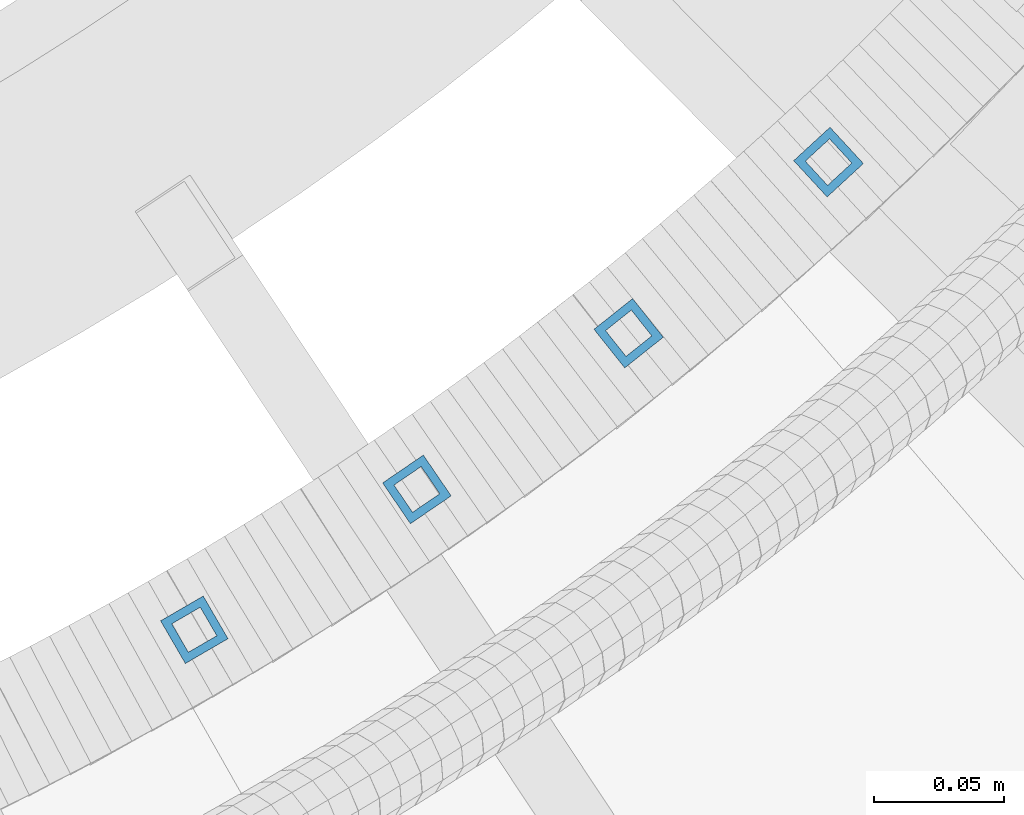
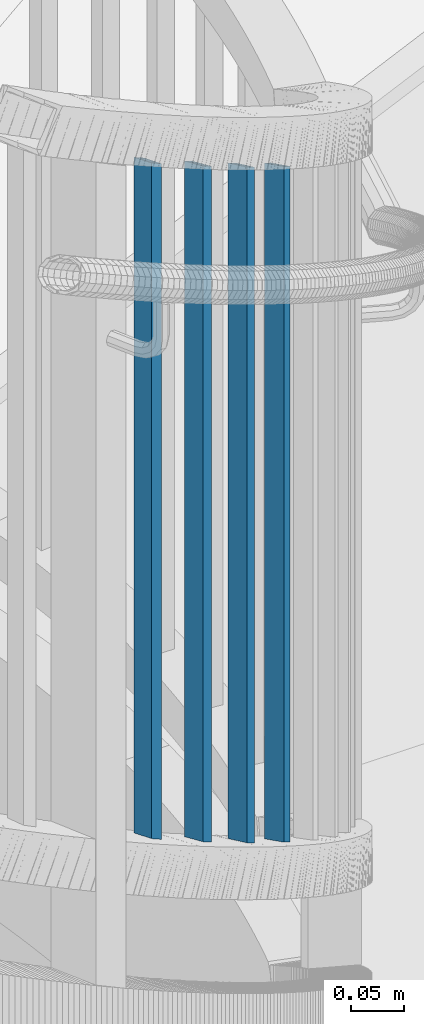
# One storey, part 259 of 975: 4 columns.
"""IFC2X3 building model written with IfcOpenShell, lengths in millimetres."""

from ifc_helpers import new_model, si_unit, frame, origin_with_axes, place, context, subcontext, project, spatial, faceted_brep, material, type_object, element, save


model = new_model("IFC2X3")

# Units and contexts
model_context = context("Model", 3, precision=1e-05, world=origin_with_axes())
body_context = subcontext(model_context, "Body", "Model", "MODEL_VIEW")
ifc_project = project(units=[si_unit("LENGTHUNIT", "METRE", prefix="MILLI"), si_unit("AREAUNIT", "SQUARE_METRE"), si_unit("VOLUMEUNIT", "CUBIC_METRE"), si_unit("MASSUNIT", "GRAM", prefix="KILO"), si_unit("TIMEUNIT", "SECOND"), si_unit("PLANEANGLEUNIT", "RADIAN"), si_unit("SOLIDANGLEUNIT", "STERADIAN"), si_unit("THERMODYNAMICTEMPERATUREUNIT", "DEGREE_CELSIUS"), si_unit("LUMINOUSINTENSITYUNIT", "LUMEN")], contexts=[model_context])

# Site, building, storey
site_placement = place(None, origin_with_axes())
site = spatial("IfcSite", under=ifc_project, at=site_placement, CompositionType="ELEMENT")
building_placement = place(site_placement, origin_with_axes())
building = spatial("IfcBuilding", under=site, at=building_placement, Name="Undefined", CompositionType="ELEMENT")
storey_placement = place(building_placement, origin_with_axes())
storey = spatial("IfcBuildingStorey", under=building, at=storey_placement, Name="Undefined", CompositionType="ELEMENT", Elevation=0.0)

# Columns
ifc_material = material()
column_type = type_object("IfcColumnType", Name="HSS3/4X3/4X.120_TUBES", PredefinedType="NOTDEFINED")
for number, where, z_axis, x_axis, name in (
    (1, (35436.091114407, 2195.81949765584, 2987.40328621885), (0.502295716094457, -0.864695908162607, 0.0), (0.0, 0.0, 1.0), "PICKET"),
    (2, (35521.9983422448, 2249.99253060321, 2920.72828621885), (0.563799962053774, -0.825911377078778, 0.0), (0.0, 0.0, 1.0), "PICKET"),
    (3, (35603.7420568337, 2310.26470012371, 2854.05328621885), (0.622323390073894, -0.782760243092951, 0.0), (0.0, 0.0, 1.0), "PICKET"),
    (4, (35680.8900781698, 2376.317346531, 2787.37828621885), (0.677556587096638, -0.735470646104898, 0.0), (0.0, 0.0, 1.0), "PICKET"),
):
    element("IfcColumn", number, at=place(storey_placement, frame(where, z_axis=z_axis, x_axis=x_axis)), inside=storey, type_object=column_type, material=ifc_material, Name=name, ObjectType="HSS3/4X3/4X.120_TUBES", context=body_context, shape_type="Brep", body=[
        faceted_brep([(81.3030822565961, 6.34999999999491, -6.34999999997672), (73.0243810963957, -6.34999999999854, -6.35000000000582), (849.31820965341, -6.34999999999854, -6.35000000000582), (857.556470281766, 6.34999999999491, -6.34999999997672), (73.0243810963952, -6.34999999999127, 6.34999999998399), (849.318209653409, -6.34999999999127, 6.34999999998399), (81.3030822565956, 6.35000000000218, 6.34999999999854), (857.556470281765, 6.35000000000218, 6.34999999999854), (83.3727575466464, 9.52499999999054, -9.52499999997235), (83.3727575466455, 9.52500000000509, 9.52500000000146), (859.616035438854, 9.52500000000509, 9.52500000000146), (859.616035438854, 9.52499999999054, -9.52499999997235), (70.9547058063449, -9.5249999999869, 9.52499999997235), (847.25864449632, -9.5249999999869, 9.52499999997235), (70.9547058063458, -9.52500000000146, -9.52499999999418), (847.258644496321, -9.52500000000146, -9.52499999999418)], [[[0, 1, 2, 3]], [[1, 4, 5, 2]], [[4, 6, 7, 5]], [[6, 0, 3, 7]], [[8, 9, 10, 11]], [[9, 12, 13, 10]], [[12, 14, 15, 13]], [[14, 8, 11, 15]], [[13, 15, 11, 10], [5, 7, 3, 2]], [[14, 12, 9, 8], [6, 4, 1, 0]]]),
    ])

save(model, "model.ifc")
